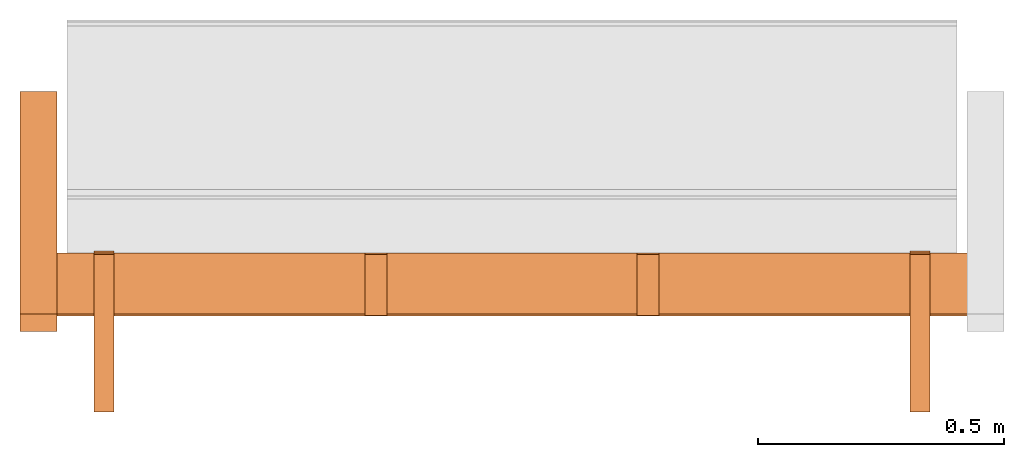
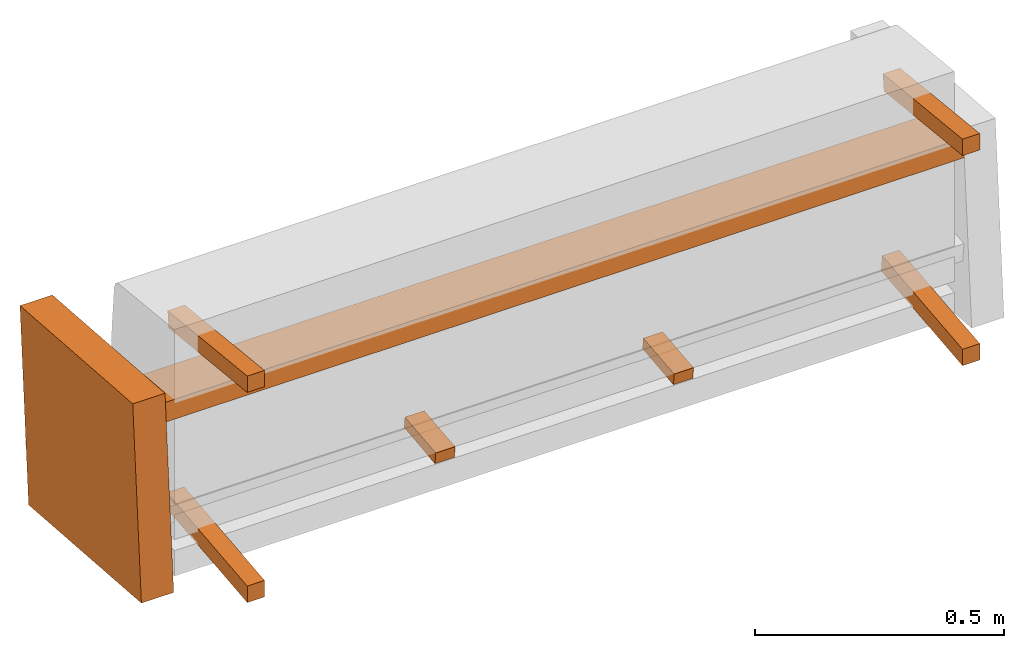
# One storey, part 3 of 4: 10 proxies, 1 element without a shape of its own.
"""IFC2X3 building model written with IfcOpenShell, lengths in metres."""

from ifc_helpers import new_model, si_unit, direction, origin_with_axes, place, context, project, spatial, faceted_brep, source, transform, mapped, element, aggregate, save


model = new_model("IFC2X3")

# Units and contexts
model_context = context("Model", 3, precision=1e-06, world=origin_with_axes(), true_north=direction((0.0, 1.0, 0.0)))
ifc_project = project(units=[si_unit("LENGTHUNIT", "METRE"), si_unit("AREAUNIT", "SQUARE_METRE"), si_unit("VOLUMEUNIT", "CUBIC_METRE")], contexts=[model_context])

# Site, building, storey
site_placement = place(None, origin_with_axes())
site = spatial("IfcSite", under=ifc_project, at=site_placement, CompositionType="ELEMENT")
building_placement = place(site_placement, origin_with_axes())
building = spatial("IfcBuilding", under=site, at=building_placement, Name="Default Building", CompositionType="ELEMENT")
storey_placement = place(building_placement, origin_with_axes())
storey = spatial("IfcBuildingStorey", under=building, at=storey_placement, Name="Default Storey", CompositionType="ELEMENT", Elevation=0.0)

# Assembly, proxies
assembly_placement = place(storey_placement, origin_with_axes())
assembly = element("IfcElementAssembly", 1, at=assembly_placement, inside=storey, Name="H-04-084-A_3-seater", ObjectType="H-04-084-A_3-seater", AssemblyPlace="NOTDEFINED", PredefinedType="NOTDEFINED")
shared_shape_1 = source(origin_with_axes(), model_context, "Body", "Brep", [
    faceted_brep([(-0.8100000023841858, -0.3086628317832947, -0.31151315569877625), (-0.8100000023841858, -0.3086628317832947, -0.2712928354740143), (-0.8500000238418579, -0.3086628317832947, -0.31151315569877625), (-0.8500000238418579, -0.3086628317832947, -0.31151315569877625), (-0.8100000023841858, -0.3086628317832947, -0.2712928354740143), (-0.8500000238418579, -0.3086628317832947, -0.2712928354740143), (-0.8100000023841858, -0.3086628317832947, -0.2712928354740143), (-0.8100000023841858, 0.014455263502895832, -0.23733174800872803), (-0.8500000238418579, -0.3086628317832947, -0.2712928354740143), (-0.8500000238418579, -0.3086628317832947, -0.2712928354740143), (-0.8100000023841858, 0.014455263502895832, -0.23733174800872803), (-0.8500000238418579, 0.014455263502895832, -0.23733174800872803), (-0.8100000023841858, 0.014455263502895832, -0.23733174800872803), (-0.8100000023841858, 0.018636401742696762, -0.2771126329898834), (-0.8500000238418579, 0.014455263502895832, -0.23733174800872803), (-0.8500000238418579, 0.014455263502895832, -0.23733174800872803), (-0.8100000023841858, 0.018636401742696762, -0.2771126329898834), (-0.8500000238418579, 0.018636401742696762, -0.2771126329898834), (-0.8100000023841858, 0.018636401742696762, -0.2771126329898834), (-0.8100000023841858, -0.3086628317832947, -0.31151315569877625), (-0.8500000238418579, 0.018636401742696762, -0.2771126329898834), (-0.8500000238418579, 0.018636401742696762, -0.2771126329898834), (-0.8100000023841858, -0.3086628317832947, -0.31151315569877625), (-0.8500000238418579, -0.3086628317832947, -0.31151315569877625), (-0.8100000023841858, 0.018636401742696762, -0.2771126329898834), (-0.8100000023841858, 0.014455263502895832, -0.23733174800872803), (-0.8100000023841858, -0.3086628317832947, -0.31151315569877625), (-0.8100000023841858, -0.3086628317832947, -0.31151315569877625), (-0.8100000023841858, 0.014455263502895832, -0.23733174800872803), (-0.8100000023841858, -0.3086628317832947, -0.2712928354740143), (-0.8500000238418579, 0.014455263502895832, -0.23733174800872803), (-0.8500000238418579, 0.018636401742696762, -0.2771126329898834), (-0.8500000238418579, -0.3086628317832947, -0.2712928354740143), (-0.8500000238418579, -0.3086628317832947, -0.2712928354740143), (-0.8500000238418579, 0.018636401742696762, -0.2771126329898834), (-0.8500000238418579, -0.3086628317832947, -0.31151315569877625)], [[[0, 1, 2]], [[3, 4, 5]], [[6, 7, 8]], [[9, 10, 11]], [[12, 13, 14]], [[15, 16, 17]], [[18, 19, 20]], [[21, 22, 23]], [[24, 25, 26]], [[27, 28, 29]], [[30, 31, 32]], [[33, 34, 35]]]),
])
proxy_1_placement = place(assembly_placement, origin_with_axes())
proxy_1 = element("IfcBuildingElementProxy", 2, at=proxy_1_placement, Name="2", ObjectType="2", CompositionType="ELEMENT", context=model_context, shape_type="MappedRepresentation", body=[
    mapped(shared_shape_1, transform((0.0, 0.0, 0.0), scale=1.0)),
])
shared_shape_2 = source(origin_with_axes(), model_context, "Body", "Brep", [
    faceted_brep([(-0.8100000023841858, 0.00747277494519949, 0.17069438099861145), (-0.8100000023841858, -0.3086836636066437, 0.203923761844635), (-0.8500000238418579, 0.00747277494519949, 0.17069438099861145), (-0.8500000238418579, 0.00747277494519949, 0.17069438099861145), (-0.8100000023841858, -0.3086836636066437, 0.203923761844635), (-0.8500000238418579, -0.3086836636066437, 0.203923761844635), (-0.8100000023841858, -0.3086836636066437, 0.203923761844635), (-0.8100000023841858, -0.3086836636066437, 0.24414409697055817), (-0.8500000238418579, -0.3086836636066437, 0.203923761844635), (-0.8500000238418579, -0.3086836636066437, 0.203923761844635), (-0.8100000023841858, -0.3086836636066437, 0.24414409697055817), (-0.8500000238418579, -0.3086836636066437, 0.24414409697055817), (-0.8100000023841858, -0.3086836636066437, 0.24414409697055817), (-0.8100000023841858, 0.011653914116322994, 0.21047525107860565), (-0.8500000238418579, -0.3086836636066437, 0.24414409697055817), (-0.8500000238418579, -0.3086836636066437, 0.24414409697055817), (-0.8100000023841858, 0.011653914116322994, 0.21047525107860565), (-0.8500000238418579, 0.011653914116322994, 0.21047525107860565), (-0.8100000023841858, 0.011653914116322994, 0.21047525107860565), (-0.8100000023841858, 0.00747277494519949, 0.17069438099861145), (-0.8500000238418579, 0.011653914116322994, 0.21047525107860565), (-0.8500000238418579, 0.011653914116322994, 0.21047525107860565), (-0.8100000023841858, 0.00747277494519949, 0.17069438099861145), (-0.8500000238418579, 0.00747277494519949, 0.17069438099861145), (-0.8100000023841858, 0.011653914116322994, 0.21047525107860565), (-0.8100000023841858, -0.3086836636066437, 0.24414409697055817), (-0.8100000023841858, 0.00747277494519949, 0.17069438099861145), (-0.8100000023841858, 0.00747277494519949, 0.17069438099861145), (-0.8100000023841858, -0.3086836636066437, 0.24414409697055817), (-0.8100000023841858, -0.3086836636066437, 0.203923761844635), (-0.8500000238418579, -0.3086836636066437, 0.24414409697055817), (-0.8500000238418579, 0.011653914116322994, 0.21047525107860565), (-0.8500000238418579, -0.3086836636066437, 0.203923761844635), (-0.8500000238418579, -0.3086836636066437, 0.203923761844635), (-0.8500000238418579, 0.011653914116322994, 0.21047525107860565), (-0.8500000238418579, 0.00747277494519949, 0.17069438099861145)], [[[0, 1, 2]], [[3, 4, 5]], [[6, 7, 8]], [[9, 10, 11]], [[12, 13, 14]], [[15, 16, 17]], [[18, 19, 20]], [[21, 22, 23]], [[24, 25, 26]], [[27, 28, 29]], [[30, 31, 32]], [[33, 34, 35]]]),
])
proxy_2_placement = place(assembly_placement, origin_with_axes())
proxy_2 = element("IfcBuildingElementProxy", 3, at=proxy_2_placement, Name="3", ObjectType="3", CompositionType="ELEMENT", context=model_context, shape_type="MappedRepresentation", body=[
    mapped(shared_shape_2, transform((0.0, 0.0, 0.0), scale=1.0)),
])
shared_shape_3 = source(origin_with_axes(), model_context, "Body", "Brep", [
    faceted_brep([(0.8500000238418579, 0.00747277494519949, 0.17069438099861145), (0.8500000238418579, -0.3086836636066437, 0.203923761844635), (0.8100000023841858, 0.00747277494519949, 0.17069438099861145), (0.8100000023841858, 0.00747277494519949, 0.17069438099861145), (0.8500000238418579, -0.3086836636066437, 0.203923761844635), (0.8100000023841858, -0.3086836636066437, 0.203923761844635), (0.8500000238418579, -0.3086836636066437, 0.203923761844635), (0.8500000238418579, -0.3086836636066437, 0.24414409697055817), (0.8100000023841858, -0.3086836636066437, 0.203923761844635), (0.8100000023841858, -0.3086836636066437, 0.203923761844635), (0.8500000238418579, -0.3086836636066437, 0.24414409697055817), (0.8100000023841858, -0.3086836636066437, 0.24414409697055817), (0.8500000238418579, -0.3086836636066437, 0.24414409697055817), (0.8500000238418579, 0.011653914116322994, 0.21047525107860565), (0.8100000023841858, -0.3086836636066437, 0.24414409697055817), (0.8100000023841858, -0.3086836636066437, 0.24414409697055817), (0.8500000238418579, 0.011653914116322994, 0.21047525107860565), (0.8100000023841858, 0.011653914116322994, 0.21047525107860565), (0.8500000238418579, 0.011653914116322994, 0.21047525107860565), (0.8500000238418579, 0.00747277494519949, 0.17069438099861145), (0.8100000023841858, 0.011653914116322994, 0.21047525107860565), (0.8100000023841858, 0.011653914116322994, 0.21047525107860565), (0.8500000238418579, 0.00747277494519949, 0.17069438099861145), (0.8100000023841858, 0.00747277494519949, 0.17069438099861145), (0.8500000238418579, 0.011653914116322994, 0.21047525107860565), (0.8500000238418579, -0.3086836636066437, 0.24414409697055817), (0.8500000238418579, 0.00747277494519949, 0.17069438099861145), (0.8500000238418579, 0.00747277494519949, 0.17069438099861145), (0.8500000238418579, -0.3086836636066437, 0.24414409697055817), (0.8500000238418579, -0.3086836636066437, 0.203923761844635), (0.8100000023841858, -0.3086836636066437, 0.24414409697055817), (0.8100000023841858, 0.011653914116322994, 0.21047525107860565), (0.8100000023841858, -0.3086836636066437, 0.203923761844635), (0.8100000023841858, -0.3086836636066437, 0.203923761844635), (0.8100000023841858, 0.011653914116322994, 0.21047525107860565), (0.8100000023841858, 0.00747277494519949, 0.17069438099861145)], [[[0, 1, 2]], [[3, 4, 5]], [[6, 7, 8]], [[9, 10, 11]], [[12, 13, 14]], [[15, 16, 17]], [[18, 19, 20]], [[21, 22, 23]], [[24, 25, 26]], [[27, 28, 29]], [[30, 31, 32]], [[33, 34, 35]]]),
])
proxy_3_placement = place(assembly_placement, origin_with_axes())
proxy_3 = element("IfcBuildingElementProxy", 4, at=proxy_3_placement, Name="4", ObjectType="4", CompositionType="ELEMENT", context=model_context, shape_type="MappedRepresentation", body=[
    mapped(shared_shape_3, transform((0.0, 0.0, 0.0), scale=1.0)),
])
shared_shape_4 = source(origin_with_axes(), model_context, "Body", "Brep", [
    faceted_brep([(0.8500000238418579, -0.3086628317832947, -0.31151315569877625), (0.8500000238418579, -0.3086628317832947, -0.2712928354740143), (0.8100000023841858, -0.3086628317832947, -0.31151315569877625), (0.8100000023841858, -0.3086628317832947, -0.31151315569877625), (0.8500000238418579, -0.3086628317832947, -0.2712928354740143), (0.8100000023841858, -0.3086628317832947, -0.2712928354740143), (0.8500000238418579, -0.3086628317832947, -0.2712928354740143), (0.8500000238418579, 0.014455263502895832, -0.23733174800872803), (0.8100000023841858, -0.3086628317832947, -0.2712928354740143), (0.8100000023841858, -0.3086628317832947, -0.2712928354740143), (0.8500000238418579, 0.014455263502895832, -0.23733174800872803), (0.8100000023841858, 0.014455263502895832, -0.23733174800872803), (0.8500000238418579, 0.014455263502895832, -0.23733174800872803), (0.8500000238418579, 0.018636401742696762, -0.2771126329898834), (0.8100000023841858, 0.014455263502895832, -0.23733174800872803), (0.8100000023841858, 0.014455263502895832, -0.23733174800872803), (0.8500000238418579, 0.018636401742696762, -0.2771126329898834), (0.8100000023841858, 0.018636401742696762, -0.2771126329898834), (0.8500000238418579, 0.018636401742696762, -0.2771126329898834), (0.8500000238418579, -0.3086628317832947, -0.31151315569877625), (0.8100000023841858, 0.018636401742696762, -0.2771126329898834), (0.8100000023841858, 0.018636401742696762, -0.2771126329898834), (0.8500000238418579, -0.3086628317832947, -0.31151315569877625), (0.8100000023841858, -0.3086628317832947, -0.31151315569877625), (0.8500000238418579, 0.018636401742696762, -0.2771126329898834), (0.8500000238418579, 0.014455263502895832, -0.23733174800872803), (0.8500000238418579, -0.3086628317832947, -0.31151315569877625), (0.8500000238418579, -0.3086628317832947, -0.31151315569877625), (0.8500000238418579, 0.014455263502895832, -0.23733174800872803), (0.8500000238418579, -0.3086628317832947, -0.2712928354740143), (0.8100000023841858, 0.014455263502895832, -0.23733174800872803), (0.8100000023841858, 0.018636401742696762, -0.2771126329898834), (0.8100000023841858, -0.3086628317832947, -0.2712928354740143), (0.8100000023841858, -0.3086628317832947, -0.2712928354740143), (0.8100000023841858, 0.018636401742696762, -0.2771126329898834), (0.8100000023841858, -0.3086628317832947, -0.31151315569877625)], [[[0, 1, 2]], [[3, 4, 5]], [[6, 7, 8]], [[9, 10, 11]], [[12, 13, 14]], [[15, 16, 17]], [[18, 19, 20]], [[21, 22, 23]], [[24, 25, 26]], [[27, 28, 29]], [[30, 31, 32]], [[33, 34, 35]]]),
])
proxy_4_placement = place(assembly_placement, origin_with_axes())
proxy_4 = element("IfcBuildingElementProxy", 5, at=proxy_4_placement, Name="5", ObjectType="5", CompositionType="ELEMENT", context=model_context, shape_type="MappedRepresentation", body=[
    mapped(shared_shape_4, transform((0.0, 0.0, 0.0), scale=1.0)),
])
shared_shape_5 = source(origin_with_axes(), model_context, "Body", "Brep", [
    faceted_brep([(-0.2991666793823242, -0.10928957164287567, -0.2845251262187958), (-0.2991666793823242, 0.015025665983557701, -0.27145907282829285), (-0.2541666626930237, -0.10928957164287567, -0.2845251262187958), (-0.2541666626930237, -0.10928957164287567, -0.2845251262187958), (-0.2991666793823242, 0.015025665983557701, -0.27145907282829285), (-0.2541666626930237, 0.015025665983557701, -0.27145907282829285), (-0.2991666793823242, -0.11221636831760406, -0.2566785216331482), (-0.2991666793823242, -0.10928957164287567, -0.2845251262187958), (-0.2541666626930237, -0.11221636831760406, -0.2566785216331482), (-0.2541666626930237, -0.11221636831760406, -0.2566785216331482), (-0.2991666793823242, -0.10928957164287567, -0.2845251262187958), (-0.2541666626930237, -0.10928957164287567, -0.2845251262187958), (-0.2991666793823242, 0.012098868377506733, -0.24361246824264526), (-0.2991666793823242, -0.11221636831760406, -0.2566785216331482), (-0.2541666626930237, 0.012098868377506733, -0.24361246824264526), (-0.2541666626930237, 0.012098868377506733, -0.24361246824264526), (-0.2991666793823242, -0.11221636831760406, -0.2566785216331482), (-0.2541666626930237, -0.11221636831760406, -0.2566785216331482), (-0.2991666793823242, 0.015025665983557701, -0.27145907282829285), (-0.2991666793823242, 0.012098868377506733, -0.24361246824264526), (-0.2541666626930237, 0.015025665983557701, -0.27145907282829285), (-0.2541666626930237, 0.015025665983557701, -0.27145907282829285), (-0.2991666793823242, 0.012098868377506733, -0.24361246824264526), (-0.2541666626930237, 0.012098868377506733, -0.24361246824264526), (-0.2991666793823242, -0.11221636831760406, -0.2566785216331482), (-0.2991666793823242, 0.012098868377506733, -0.24361246824264526), (-0.2991666793823242, -0.10928957164287567, -0.2845251262187958), (-0.2991666793823242, -0.10928957164287567, -0.2845251262187958), (-0.2991666793823242, 0.012098868377506733, -0.24361246824264526), (-0.2991666793823242, 0.015025665983557701, -0.27145907282829285), (-0.2541666626930237, 0.012098868377506733, -0.24361246824264526), (-0.2541666626930237, -0.11221636831760406, -0.2566785216331482), (-0.2541666626930237, 0.015025665983557701, -0.27145907282829285), (-0.2541666626930237, 0.015025665983557701, -0.27145907282829285), (-0.2541666626930237, -0.11221636831760406, -0.2566785216331482), (-0.2541666626930237, -0.10928957164287567, -0.2845251262187958)], [[[0, 1, 2]], [[3, 4, 5]], [[6, 7, 8]], [[9, 10, 11]], [[12, 13, 14]], [[15, 16, 17]], [[18, 19, 20]], [[21, 22, 23]], [[24, 25, 26]], [[27, 28, 29]], [[30, 31, 32]], [[33, 34, 35]]]),
])
proxy_5_placement = place(assembly_placement, origin_with_axes())
proxy_5 = element("IfcBuildingElementProxy", 6, at=proxy_5_placement, Name="7", ObjectType="7", CompositionType="ELEMENT", context=model_context, shape_type="MappedRepresentation", body=[
    mapped(shared_shape_5, transform((0.0, 0.0, 0.0), scale=1.0)),
])
shared_shape_6 = source(origin_with_axes(), model_context, "Body", "Brep", [
    faceted_brep([(0.2541666626930237, -0.10928957164287567, -0.2845251262187958), (0.2541666626930237, 0.015025665983557701, -0.27145907282829285), (0.2991666793823242, -0.10928957164287567, -0.2845251262187958), (0.2991666793823242, -0.10928957164287567, -0.2845251262187958), (0.2541666626930237, 0.015025665983557701, -0.27145907282829285), (0.2991666793823242, 0.015025665983557701, -0.27145907282829285), (0.2541666626930237, -0.11221636831760406, -0.2566785216331482), (0.2541666626930237, -0.10928957164287567, -0.2845251262187958), (0.2991666793823242, -0.11221636831760406, -0.2566785216331482), (0.2991666793823242, -0.11221636831760406, -0.2566785216331482), (0.2541666626930237, -0.10928957164287567, -0.2845251262187958), (0.2991666793823242, -0.10928957164287567, -0.2845251262187958), (0.2541666626930237, 0.012098868377506733, -0.24361246824264526), (0.2541666626930237, -0.11221636831760406, -0.2566785216331482), (0.2991666793823242, 0.012098868377506733, -0.24361246824264526), (0.2991666793823242, 0.012098868377506733, -0.24361246824264526), (0.2541666626930237, -0.11221636831760406, -0.2566785216331482), (0.2991666793823242, -0.11221636831760406, -0.2566785216331482), (0.2541666626930237, 0.015025665983557701, -0.27145907282829285), (0.2541666626930237, 0.012098868377506733, -0.24361246824264526), (0.2991666793823242, 0.015025665983557701, -0.27145907282829285), (0.2991666793823242, 0.015025665983557701, -0.27145907282829285), (0.2541666626930237, 0.012098868377506733, -0.24361246824264526), (0.2991666793823242, 0.012098868377506733, -0.24361246824264526), (0.2541666626930237, -0.11221636831760406, -0.2566785216331482), (0.2541666626930237, 0.012098868377506733, -0.24361246824264526), (0.2541666626930237, -0.10928957164287567, -0.2845251262187958), (0.2541666626930237, -0.10928957164287567, -0.2845251262187958), (0.2541666626930237, 0.012098868377506733, -0.24361246824264526), (0.2541666626930237, 0.015025665983557701, -0.27145907282829285), (0.2991666793823242, 0.012098868377506733, -0.24361246824264526), (0.2991666793823242, -0.11221636831760406, -0.2566785216331482), (0.2991666793823242, 0.015025665983557701, -0.27145907282829285), (0.2991666793823242, 0.015025665983557701, -0.27145907282829285), (0.2991666793823242, -0.11221636831760406, -0.2566785216331482), (0.2991666793823242, -0.10928957164287567, -0.2845251262187958)], [[[0, 1, 2]], [[3, 4, 5]], [[6, 7, 8]], [[9, 10, 11]], [[12, 13, 14]], [[15, 16, 17]], [[18, 19, 20]], [[21, 22, 23]], [[24, 25, 26]], [[27, 28, 29]], [[30, 31, 32]], [[33, 34, 35]]]),
])
proxy_6_placement = place(assembly_placement, origin_with_axes())
proxy_6 = element("IfcBuildingElementProxy", 7, at=proxy_6_placement, Name="8", ObjectType="8", CompositionType="ELEMENT", context=model_context, shape_type="MappedRepresentation", body=[
    mapped(shared_shape_6, transform((0.0, 0.0, 0.0), scale=1.0)),
])
shared_shape_7 = source(origin_with_axes(), model_context, "Body", "Brep", [
    faceted_brep([(0.9280000329017639, -0.1089811846613884, 0.08462798595428467), (0.9280000329017639, 0.01533420942723751, 0.07156191021203995), (-0.9279999732971191, -0.10898102819919586, 0.08462949097156525), (-0.9279999732971191, -0.10898102819919586, 0.08462949097156525), (0.9280000329017639, 0.01533420942723751, 0.07156191021203995), (-0.9279999732971191, 0.015334367752075195, 0.07156341522932053), (0.9279999732971191, -0.11368496716022491, 0.039874475449323654), (0.9280000329017639, -0.1089811846613884, 0.08462798595428467), (-0.9280000329017639, -0.11368481069803238, 0.03987598419189453), (-0.9280000329017639, -0.11368481069803238, 0.03987598419189453), (0.9280000329017639, -0.1089811846613884, 0.08462798595428467), (-0.9279999732971191, -0.10898102819919586, 0.08462949097156525), (0.9279999732971191, 0.010630425997078419, 0.026808401569724083), (0.9279999732971191, -0.11368496716022491, 0.039874475449323654), (-0.9280000329017639, 0.010630584321916103, 0.02680990844964981), (-0.9280000329017639, 0.010630584321916103, 0.02680990844964981), (0.9279999732971191, -0.11368496716022491, 0.039874475449323654), (-0.9280000329017639, -0.11368481069803238, 0.03987598419189453), (0.9280000329017639, 0.01533420942723751, 0.07156191021203995), (0.9279999732971191, 0.010630425997078419, 0.026808401569724083), (-0.9279999732971191, 0.015334367752075195, 0.07156341522932053), (-0.9279999732971191, 0.015334367752075195, 0.07156341522932053), (0.9279999732971191, 0.010630425997078419, 0.026808401569724083), (-0.9280000329017639, 0.010630584321916103, 0.02680990844964981), (0.9279999732971191, -0.11368496716022491, 0.039874475449323654), (0.9279999732971191, 0.010630425997078419, 0.026808401569724083), (0.9280000329017639, -0.1089811846613884, 0.08462798595428467), (0.9280000329017639, -0.1089811846613884, 0.08462798595428467), (0.9279999732971191, 0.010630425997078419, 0.026808401569724083), (0.9280000329017639, 0.01533420942723751, 0.07156191021203995), (-0.9280000329017639, 0.010630584321916103, 0.02680990844964981), (-0.9280000329017639, -0.11368481069803238, 0.03987598419189453), (-0.9279999732971191, 0.015334367752075195, 0.07156341522932053), (-0.9279999732971191, 0.015334367752075195, 0.07156341522932053), (-0.9280000329017639, -0.11368481069803238, 0.03987598419189453), (-0.9279999732971191, -0.10898102819919586, 0.08462949097156525)], [[[0, 1, 2]], [[3, 4, 5]], [[6, 7, 8]], [[9, 10, 11]], [[12, 13, 14]], [[15, 16, 17]], [[18, 19, 20]], [[21, 22, 23]], [[24, 25, 26]], [[27, 28, 29]], [[30, 31, 32]], [[33, 34, 35]]]),
])
proxy_7_placement = place(assembly_placement, origin_with_axes())
proxy_7 = element("IfcBuildingElementProxy", 8, at=proxy_7_placement, Name="11", ObjectType="11", CompositionType="ELEMENT", context=model_context, shape_type="MappedRepresentation", body=[
    mapped(shared_shape_7, transform((0.0, 0.0, 0.0), scale=1.0)),
])
shared_shape_8 = source(origin_with_axes(), model_context, "Body", "Brep", [
    faceted_brep([(-0.2991666793823242, -0.10928957164287567, -0.2845251262187958), (-0.2991666793823242, 0.015025665983557701, -0.27145907282829285), (-0.2541666626930237, -0.10928957164287567, -0.2845251262187958), (-0.2541666626930237, -0.10928957164287567, -0.2845251262187958), (-0.2991666793823242, 0.015025665983557701, -0.27145907282829285), (-0.2541666626930237, 0.015025665983557701, -0.27145907282829285), (-0.2991666793823242, -0.11221636831760406, -0.2566785216331482), (-0.2991666793823242, -0.10928957164287567, -0.2845251262187958), (-0.2541666626930237, -0.11221636831760406, -0.2566785216331482), (-0.2541666626930237, -0.11221636831760406, -0.2566785216331482), (-0.2991666793823242, -0.10928957164287567, -0.2845251262187958), (-0.2541666626930237, -0.10928957164287567, -0.2845251262187958), (-0.2991666793823242, 0.012098868377506733, -0.24361246824264526), (-0.2991666793823242, -0.11221636831760406, -0.2566785216331482), (-0.2541666626930237, 0.012098868377506733, -0.24361246824264526), (-0.2541666626930237, 0.012098868377506733, -0.24361246824264526), (-0.2991666793823242, -0.11221636831760406, -0.2566785216331482), (-0.2541666626930237, -0.11221636831760406, -0.2566785216331482), (-0.2991666793823242, 0.015025665983557701, -0.27145907282829285), (-0.2991666793823242, 0.012098868377506733, -0.24361246824264526), (-0.2541666626930237, 0.015025665983557701, -0.27145907282829285), (-0.2541666626930237, 0.015025665983557701, -0.27145907282829285), (-0.2991666793823242, 0.012098868377506733, -0.24361246824264526), (-0.2541666626930237, 0.012098868377506733, -0.24361246824264526), (-0.2991666793823242, -0.11221636831760406, -0.2566785216331482), (-0.2991666793823242, 0.012098868377506733, -0.24361246824264526), (-0.2991666793823242, -0.10928957164287567, -0.2845251262187958), (-0.2991666793823242, -0.10928957164287567, -0.2845251262187958), (-0.2991666793823242, 0.012098868377506733, -0.24361246824264526), (-0.2991666793823242, 0.015025665983557701, -0.27145907282829285), (-0.2541666626930237, 0.012098868377506733, -0.24361246824264526), (-0.2541666626930237, -0.11221636831760406, -0.2566785216331482), (-0.2541666626930237, 0.015025665983557701, -0.27145907282829285), (-0.2541666626930237, 0.015025665983557701, -0.27145907282829285), (-0.2541666626930237, -0.11221636831760406, -0.2566785216331482), (-0.2541666626930237, -0.10928957164287567, -0.2845251262187958)], [[[0, 1, 2]], [[3, 4, 5]], [[6, 7, 8]], [[9, 10, 11]], [[12, 13, 14]], [[15, 16, 17]], [[18, 19, 20]], [[21, 22, 23]], [[24, 25, 26]], [[27, 28, 29]], [[30, 31, 32]], [[33, 34, 35]]]),
])
proxy_8_placement = place(assembly_placement, origin_with_axes())
proxy_8 = element("IfcBuildingElementProxy", 9, at=proxy_8_placement, Name="12", ObjectType="12", CompositionType="ELEMENT", context=model_context, shape_type="MappedRepresentation", body=[
    mapped(shared_shape_8, transform((0.0, 0.0, 0.0), scale=1.0)),
])
shared_shape_9 = source(origin_with_axes(), model_context, "Body", "Brep", [
    faceted_brep([(0.2541666626930237, -0.10928957164287567, -0.2845251262187958), (0.2541666626930237, 0.015025665983557701, -0.27145907282829285), (0.2991666793823242, -0.10928957164287567, -0.2845251262187958), (0.2991666793823242, -0.10928957164287567, -0.2845251262187958), (0.2541666626930237, 0.015025665983557701, -0.27145907282829285), (0.2991666793823242, 0.015025665983557701, -0.27145907282829285), (0.2541666626930237, -0.11221636831760406, -0.2566785216331482), (0.2541666626930237, -0.10928957164287567, -0.2845251262187958), (0.2991666793823242, -0.11221636831760406, -0.2566785216331482), (0.2991666793823242, -0.11221636831760406, -0.2566785216331482), (0.2541666626930237, -0.10928957164287567, -0.2845251262187958), (0.2991666793823242, -0.10928957164287567, -0.2845251262187958), (0.2541666626930237, 0.012098868377506733, -0.24361246824264526), (0.2541666626930237, -0.11221636831760406, -0.2566785216331482), (0.2991666793823242, 0.012098868377506733, -0.24361246824264526), (0.2991666793823242, 0.012098868377506733, -0.24361246824264526), (0.2541666626930237, -0.11221636831760406, -0.2566785216331482), (0.2991666793823242, -0.11221636831760406, -0.2566785216331482), (0.2541666626930237, 0.015025665983557701, -0.27145907282829285), (0.2541666626930237, 0.012098868377506733, -0.24361246824264526), (0.2991666793823242, 0.015025665983557701, -0.27145907282829285), (0.2991666793823242, 0.015025665983557701, -0.27145907282829285), (0.2541666626930237, 0.012098868377506733, -0.24361246824264526), (0.2991666793823242, 0.012098868377506733, -0.24361246824264526), (0.2541666626930237, -0.11221636831760406, -0.2566785216331482), (0.2541666626930237, 0.012098868377506733, -0.24361246824264526), (0.2541666626930237, -0.10928957164287567, -0.2845251262187958), (0.2541666626930237, -0.10928957164287567, -0.2845251262187958), (0.2541666626930237, 0.012098868377506733, -0.24361246824264526), (0.2541666626930237, 0.015025665983557701, -0.27145907282829285), (0.2991666793823242, 0.012098868377506733, -0.24361246824264526), (0.2991666793823242, -0.11221636831760406, -0.2566785216331482), (0.2991666793823242, 0.015025665983557701, -0.27145907282829285), (0.2991666793823242, 0.015025665983557701, -0.27145907282829285), (0.2991666793823242, -0.11221636831760406, -0.2566785216331482), (0.2991666793823242, -0.10928957164287567, -0.2845251262187958)], [[[0, 1, 2]], [[3, 4, 5]], [[6, 7, 8]], [[9, 10, 11]], [[12, 13, 14]], [[15, 16, 17]], [[18, 19, 20]], [[21, 22, 23]], [[24, 25, 26]], [[27, 28, 29]], [[30, 31, 32]], [[33, 34, 35]]]),
])
proxy_9_placement = place(assembly_placement, origin_with_axes())
proxy_9 = element("IfcBuildingElementProxy", 10, at=proxy_9_placement, Name="13", ObjectType="13", CompositionType="ELEMENT", context=model_context, shape_type="MappedRepresentation", body=[
    mapped(shared_shape_9, transform((0.0, 0.0, 0.0), scale=1.0)),
])
shared_shape_10 = source(origin_with_axes(), model_context, "Body", "Brep", [
    faceted_brep([(-0.9259999990463257, -0.14447768032550812, -0.3596019148826599), (-0.9259999990463257, 0.3086635172367096, -0.3933081328868866), (-0.9259999990463257, -0.1096838191151619, 0.1081613227725029), (-0.9259999990463257, -0.1096838191151619, 0.1081613227725029), (-0.9259999990463257, 0.3086635172367096, -0.3933081328868866), (-0.9259999990463257, 0.3434573709964752, 0.07445511221885681), (-1.0010000467300415, -0.14447768032550812, -0.3596019148826599), (-0.9259999990463257, -0.14447768032550812, -0.3596019148826599), (-1.0010000467300415, -0.1096838191151619, 0.1081613227725029), (-1.0010000467300415, -0.1096838191151619, 0.1081613227725029), (-0.9259999990463257, -0.14447768032550812, -0.3596019148826599), (-0.9259999990463257, -0.1096838191151619, 0.1081613227725029), (-1.0010000467300415, 0.3086635172367096, -0.3933081328868866), (-1.0010000467300415, -0.14447768032550812, -0.3596019148826599), (-1.0010000467300415, 0.3434573709964752, 0.07445511221885681), (-1.0010000467300415, 0.3434573709964752, 0.07445511221885681), (-1.0010000467300415, -0.14447768032550812, -0.3596019148826599), (-1.0010000467300415, -0.1096838191151619, 0.1081613227725029), (-0.9259999990463257, 0.3086635172367096, -0.3933081328868866), (-1.0010000467300415, 0.3086635172367096, -0.3933081328868866), (-0.9259999990463257, 0.3434573709964752, 0.07445511221885681), (-0.9259999990463257, 0.3434573709964752, 0.07445511221885681), (-1.0010000467300415, 0.3086635172367096, -0.3933081328868866), (-1.0010000467300415, 0.3434573709964752, 0.07445511221885681), (-1.0010000467300415, -0.14447768032550812, -0.3596019148826599), (-1.0010000467300415, 0.3086635172367096, -0.3933081328868866), (-0.9259999990463257, -0.14447768032550812, -0.3596019148826599), (-0.9259999990463257, -0.14447768032550812, -0.3596019148826599), (-1.0010000467300415, 0.3086635172367096, -0.3933081328868866), (-0.9259999990463257, 0.3086635172367096, -0.3933081328868866), (-1.0010000467300415, 0.3434573709964752, 0.07445511221885681), (-1.0010000467300415, -0.1096838191151619, 0.1081613227725029), (-0.9259999990463257, 0.3434573709964752, 0.07445511221885681), (-0.9259999990463257, 0.3434573709964752, 0.07445511221885681), (-1.0010000467300415, -0.1096838191151619, 0.1081613227725029), (-0.9259999990463257, -0.1096838191151619, 0.1081613227725029)], [[[0, 1, 2]], [[3, 4, 5]], [[6, 7, 8]], [[9, 10, 11]], [[12, 13, 14]], [[15, 16, 17]], [[18, 19, 20]], [[21, 22, 23]], [[24, 25, 26]], [[27, 28, 29]], [[30, 31, 32]], [[33, 34, 35]]]),
])
proxy_10_placement = place(assembly_placement, origin_with_axes())
proxy_10 = element("IfcBuildingElementProxy", 11, at=proxy_10_placement, Name="15", ObjectType="15", CompositionType="ELEMENT", context=model_context, shape_type="MappedRepresentation", body=[
    mapped(shared_shape_10, transform((0.0, 0.0, 0.0), scale=1.0)),
])
aggregate(assembly, [proxy_1, proxy_2, proxy_3, proxy_4, proxy_5, proxy_6, proxy_7, proxy_8, proxy_9, proxy_10])

save(model, "model.ifc")
